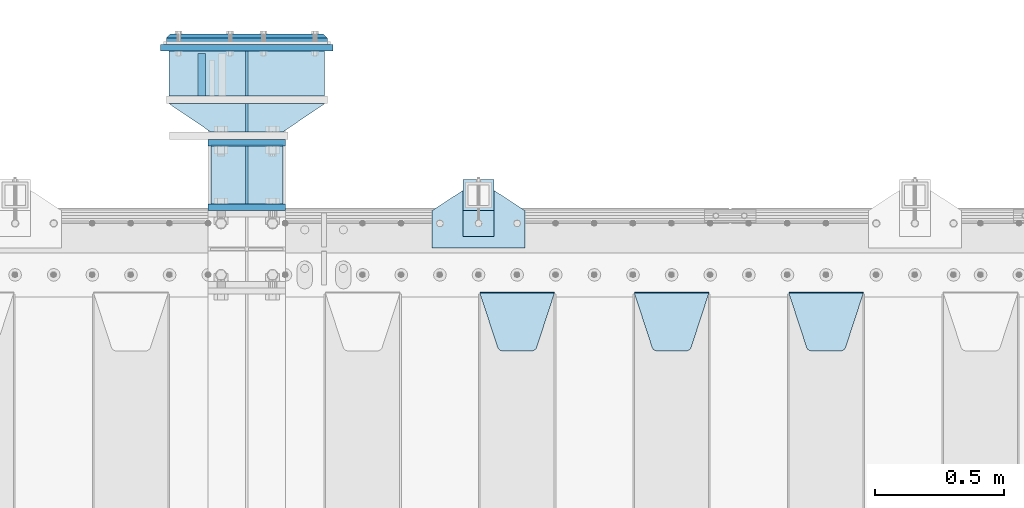
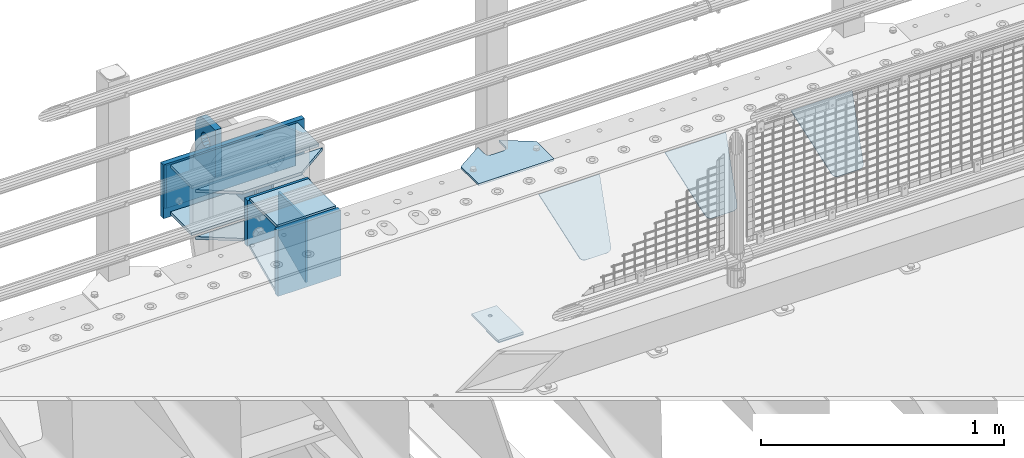
# One storey, part 232 of 257: 20 plates.
"""IFC2X3 building model written with IfcOpenShell, lengths in millimetres."""

from ifc_helpers import new_model, si_unit, frame, origin_with_axes, place, context, subcontext, project, spatial, faceted_brep, material, type_object, element, save


model = new_model("IFC2X3")

# Units and contexts
model_context = context("Model", 3, precision=1e-05, world=origin_with_axes())
body_context = subcontext(model_context, "Body", "Model", "MODEL_VIEW")
ifc_project = project(units=[si_unit("LENGTHUNIT", "METRE", prefix="MILLI"), si_unit("AREAUNIT", "SQUARE_METRE"), si_unit("VOLUMEUNIT", "CUBIC_METRE"), si_unit("MASSUNIT", "GRAM", prefix="KILO"), si_unit("TIMEUNIT", "SECOND"), si_unit("PLANEANGLEUNIT", "RADIAN"), si_unit("SOLIDANGLEUNIT", "STERADIAN"), si_unit("THERMODYNAMICTEMPERATUREUNIT", "DEGREE_CELSIUS"), si_unit("LUMINOUSINTENSITYUNIT", "LUMEN")], contexts=[model_context])

# Site, building, storey
site_placement = place(None, origin_with_axes())
site = spatial("IfcSite", under=ifc_project, at=site_placement, CompositionType="ELEMENT")
building_placement = place(site_placement, origin_with_axes())
building = spatial("IfcBuilding", under=site, at=building_placement, Name="Standard", CompositionType="ELEMENT")
storey_placement = place(building_placement, origin_with_axes())
storey = spatial("IfcBuildingStorey", under=building, at=storey_placement, Name="Undefined", CompositionType="ELEMENT", Elevation=0.0)

# Plates
ifc_material_1 = material(Name="STEEL/S355N")
plate_type_1 = type_object("IfcPlateType", PredefinedType="NOTDEFINED")
plate_1_placement = place(storey_placement, frame((54524.4999994828, 12595.0000000407, -1.9536520994734e-05), z_axis=(0.0, 1.0, 0.0), x_axis=(0.0, 0.0, 1.0)))
element("IfcPlate", 1, at=plate_1_placement, inside=storey, type_object=plate_type_1, material=ifc_material_1, context=body_context, shape_type="Brep", body=[
    faceted_brep([(125.840713002475, 15.0000005560505, 114.183542552877), (125.840713002475, -14.9999994439495, 114.183542852878), (113.837049096081, -14.9999995241524, 106.162951053862), (113.837049096081, 15.0000004758476, 106.162950753862), (105.816457297066, -14.9999996441911, 94.1592871474677), (105.816457297066, 15.0000003558089, 94.1592868474672), (102.999999999984, -14.9999997857813, 80.0000001499593), (102.999999999984, 15.0000002142187, 79.9999998499588), (105.816457297066, -14.9999999273787, 65.8407131524509), (105.816457297066, 15.0000000726213, 65.8407128524505), (113.837049096081, -15.0000000474101, 53.8370492460563), (113.837049096081, 14.9999999525899, 53.8370489460558), (125.840713002475, -15.0000001276203, 45.8164574470411), (125.840713002475, 14.9999998723797, 45.8164571470406), (139.999999999984, -15.0000001557855, 43.0000001499593), (139.999999999984, 14.9999998442145, 42.9999998499588), (154.159286997492, -15.0000001276203, 45.8164574470411), (154.159286997492, 14.9999998723797, 45.8164571470406), (166.162950903886, -15.0000000474101, 53.8370492460563), (166.162950903886, 14.9999999525899, 53.8370489460558), (174.183542702901, -14.9999999273787, 65.8407131524509), (174.183542702901, 15.0000000726213, 65.8407128524505), (176.999999999984, -14.9999997857813, 80.0000001499593), (176.999999999984, 15.0000002142187, 79.9999998499588), (174.183542702901, -14.9999996441911, 94.1592871474677), (174.183542702901, 15.0000003558089, 94.1592868474672), (166.162950903886, -14.9999995241524, 106.162951053862), (166.162950903886, 15.0000004758476, 106.162950753862), (154.159286997492, -14.9999994439495, 114.183542852878), (154.159286997492, 15.0000005560505, 114.183542552877), (139.999999999984, -14.9999994157843, 117.000000149959), (139.999999999984, 15.0000005842157, 116.999999849959), (-1.40620068123098e-06, -14.9999999999927, 165.000000000002), (170.0, -14.9999999999927, 165.0), (170.0, 15.0000000000073, 165.000000000002), (-1.40620068123098e-06, 15.0000000000073, 165.000000000002), (188.117333157176, -14.9999999999927, 162.614807840235), (188.117333157176, 15.0000000000073, 162.614807840237), (205.0, -14.9999999999927, 155.621778264911), (205.0, 15.0000000000073, 155.621778264911), (219.497474683058, -14.9999999999927, 144.497474683059), (219.497474683058, 15.0000000000073, 144.497474683059), (230.621778264911, -14.9999999999927, 130.0), (230.621778264911, 15.0000000000073, 130.000000000002), (237.614807840235, -14.9999999999927, 113.117333157177), (237.614807840235, 15.0000000000073, 113.117333157177), (240.0, -14.9999999999927, 95.0), (240.0, 15.0000000000073, 95.0000000000018), (240.000015258789, -14.9999999999927, -2.03726813197136e-10), (240.000015258789, 15.0000000000073, -2.05545802600682e-10), (0.0, -15.0, 0.0), (0.0, 15.0, 0.0)], [[[0, 1, 2, 3]], [[3, 2, 4, 5]], [[5, 4, 6, 7]], [[7, 6, 8, 9]], [[9, 8, 10, 11]], [[11, 10, 12, 13]], [[13, 12, 14, 15]], [[15, 14, 16, 17]], [[17, 16, 18, 19]], [[19, 18, 20, 21]], [[21, 20, 22, 23]], [[23, 22, 24, 25]], [[25, 24, 26, 27]], [[27, 26, 28, 29]], [[29, 28, 30, 31]], [[31, 30, 1, 0]], [[32, 33, 34, 35]], [[33, 36, 37, 34]], [[36, 38, 39, 37]], [[38, 40, 41, 39]], [[40, 42, 43, 41]], [[42, 44, 45, 43]], [[44, 46, 47, 45]], [[46, 48, 49, 47]], [[48, 50, 51, 49]], [[34, 37, 39, 41, 43, 45, 47, 49, 51, 35], [3, 5, 7, 9, 11, 13, 15, 17, 19, 21, 23, 25, 27, 29, 31, 0]], [[50, 32, 35, 51]], [[48, 46, 44, 42, 40, 38, 36, 33, 32, 50], [26, 24, 22, 20, 18, 16, 14, 12, 10, 8, 6, 4, 2, 1, 30, 28]]]),
])
plate_type_2 = type_object("IfcPlateType", PredefinedType="NOTDEFINED")
plate_2_placement = place(storey_placement, frame((54550.0, 12162.5000000042, -340.000019536857), z_axis=(0.0, 0.0, 1.0), x_axis=(1.0, 0.0, 0.0)))
element("IfcPlate", 2, at=plate_2_placement, inside=storey, type_object=plate_type_2, material=ifc_material_1, context=body_context, shape_type="Brep", body=[
    faceted_brep([(0.0, -12.5, 0.0), (0.0, -12.5, 330.0), (0.0, 12.5, 330.0), (0.0, 12.5, 0.0), (300.0, -12.5, 330.0), (300.0, 12.5, 330.0), (300.0, -12.5, 0.0), (300.0, 12.5, 0.0)], [[[0, 1, 2, 3]], [[1, 4, 5, 2]], [[4, 6, 7, 5]], [[6, 0, 3, 7]], [[5, 7, 3, 2]], [[6, 4, 1, 0]]]),
])
plate_type_3 = type_object("IfcPlateType", PredefinedType="NOTDEFINED")
plate_3_placement = place(storey_placement, frame((56805.0, 11831.7677669559, -1.767766952965), z_axis=(0.0, -0.707106781186548, -0.707106781186547), x_axis=(1.0, 0.0, 0.0)))
element("IfcPlate", 3, at=plate_3_placement, inside=storey, type_object=plate_type_3, material=ifc_material_1, context=body_context, shape_type="Brep", body=[
    faceted_brep([(0.0, -2.5, 0.0), (69.345504679477, -2.50000000000091, 300.17173142483), (69.345504679477, 2.5, 300.171731424831), (0.0, 2.5, 0.0), (70.927406119954, -2.50000000000091, 304.8974424154), (70.927406119954, 2.5, 304.8974424154), (73.3818627772271, -2.50000000000091, 309.234538108527), (73.3818627772271, 2.49999999999909, 309.234538108527), (76.6187032999587, -2.5, 313.023683126103), (76.6187032999587, 2.5, 313.023683126103), (80.5190132705029, -2.5, 316.125672595372), (80.5190132705029, 2.5, 316.125672595371), (84.9395038596849, -2.5, 318.426546230476), (84.9395038596849, 2.5, 318.426546230477), (89.7177759439219, -2.5, 319.841774983275), (89.7177759439219, 2.5, 319.841774983275), (94.6782862926484, -2.5, 320.319366455079), (94.6782862926484, 2.5, 320.319366455079), (195.321713707352, -2.5, 320.319366455079), (195.321713707352, 2.5, 320.319366455079), (200.282224056078, -2.5, 319.841774983275), (200.282224056078, 2.49999999999909, 319.841774983275), (205.060496140315, -2.5, 318.426546230476), (205.060496140315, 2.49999999999909, 318.426546230475), (209.480986729497, -2.5, 316.125672595371), (209.480986729497, 2.5, 316.125672595371), (213.381296700041, -2.50000000000091, 313.023683126102), (213.381296700041, 2.5, 313.023683126103), (216.618137222766, -2.50000000000091, 309.234538108527), (216.618137222766, 2.5, 309.234538108527), (219.072593880039, -2.5, 304.897442415399), (219.072593880039, 2.5, 304.897442415399), (220.654495320523, -2.50000000000091, 300.17173142483), (220.654495320523, 2.5, 300.171731424831), (290.0, -2.50000000000091, 0.0), (290.0, 2.5, 9.09494701772928e-13)], [[[0, 1, 2, 3]], [[1, 4, 5, 2]], [[4, 6, 7, 5]], [[6, 8, 9, 7]], [[8, 10, 11, 9]], [[10, 12, 13, 11]], [[12, 14, 15, 13]], [[14, 16, 17, 15]], [[16, 18, 19, 17]], [[18, 20, 21, 19]], [[20, 22, 23, 21]], [[22, 24, 25, 23]], [[24, 26, 27, 25]], [[26, 28, 29, 27]], [[28, 30, 31, 29]], [[30, 32, 33, 31]], [[32, 34, 35, 33]], [[34, 0, 3, 35]], [[5, 7, 9, 11, 13, 15, 17, 19, 21, 23, 25, 27, 29, 31, 33, 35, 3, 2]], [[34, 32, 30, 28, 26, 24, 22, 20, 18, 16, 14, 12, 10, 8, 6, 4, 1, 0]]]),
])
plate_4_placement = place(storey_placement, frame((56205.0, 11831.7677669559, -1.767766952965), z_axis=(0.0, -0.707106781186548, -0.707106781186547), x_axis=(1.0, 0.0, 0.0)))
element("IfcPlate", 4, at=plate_4_placement, inside=storey, type_object=plate_type_3, material=ifc_material_1, context=body_context, shape_type="Brep", body=[
    faceted_brep([(0.0, -2.5, 0.0), (69.345504679477, -2.50000000000091, 300.17173142483), (69.345504679477, 2.5, 300.171731424831), (0.0, 2.5, 0.0), (70.927406119954, -2.50000000000091, 304.8974424154), (70.927406119954, 2.5, 304.8974424154), (73.3818627772271, -2.50000000000091, 309.234538108527), (73.3818627772271, 2.49999999999909, 309.234538108527), (76.6187032999587, -2.5, 313.023683126103), (76.6187032999587, 2.5, 313.023683126103), (80.5190132705029, -2.5, 316.125672595372), (80.5190132705029, 2.5, 316.125672595371), (84.9395038596849, -2.5, 318.426546230476), (84.9395038596849, 2.5, 318.426546230477), (89.7177759439219, -2.5, 319.841774983275), (89.7177759439219, 2.5, 319.841774983275), (94.6782862926484, -2.5, 320.319366455079), (94.6782862926484, 2.5, 320.319366455079), (195.321713707352, -2.5, 320.319366455079), (195.321713707352, 2.5, 320.319366455079), (200.282224056078, -2.5, 319.841774983275), (200.282224056078, 2.49999999999909, 319.841774983275), (205.060496140315, -2.5, 318.426546230476), (205.060496140315, 2.49999999999909, 318.426546230475), (209.480986729497, -2.5, 316.125672595371), (209.480986729497, 2.5, 316.125672595371), (213.381296700041, -2.50000000000091, 313.023683126102), (213.381296700041, 2.5, 313.023683126103), (216.618137222766, -2.50000000000091, 309.234538108527), (216.618137222766, 2.5, 309.234538108527), (219.072593880039, -2.5, 304.897442415399), (219.072593880039, 2.5, 304.897442415399), (220.654495320523, -2.50000000000091, 300.17173142483), (220.654495320523, 2.5, 300.171731424831), (290.0, -2.50000000000091, 0.0), (290.0, 2.5, 9.09494701772928e-13)], [[[0, 1, 2, 3]], [[1, 4, 5, 2]], [[4, 6, 7, 5]], [[6, 8, 9, 7]], [[8, 10, 11, 9]], [[10, 12, 13, 11]], [[12, 14, 15, 13]], [[14, 16, 17, 15]], [[16, 18, 19, 17]], [[18, 20, 21, 19]], [[20, 22, 23, 21]], [[22, 24, 25, 23]], [[24, 26, 27, 25]], [[26, 28, 29, 27]], [[28, 30, 31, 29]], [[30, 32, 33, 31]], [[32, 34, 35, 33]], [[34, 0, 3, 35]], [[5, 7, 9, 11, 13, 15, 17, 19, 21, 23, 25, 27, 29, 31, 33, 35, 3, 2]], [[34, 32, 30, 28, 26, 24, 22, 20, 18, 16, 14, 12, 10, 8, 6, 4, 1, 0]]]),
])
plate_5_placement = place(storey_placement, frame((55605.0, 11831.7677669559, -1.767766952965), z_axis=(0.0, -0.707106781186548, -0.707106781186547), x_axis=(1.0, 0.0, 0.0)))
element("IfcPlate", 5, at=plate_5_placement, inside=storey, type_object=plate_type_3, material=ifc_material_1, context=body_context, shape_type="Brep", body=[
    faceted_brep([(0.0, -2.5, 0.0), (69.345504679477, -2.50000000000091, 300.17173142483), (69.345504679477, 2.5, 300.171731424831), (0.0, 2.5, 0.0), (70.927406119954, -2.50000000000091, 304.8974424154), (70.927406119954, 2.5, 304.8974424154), (73.3818627772271, -2.50000000000091, 309.234538108527), (73.3818627772271, 2.49999999999909, 309.234538108527), (76.6187032999587, -2.5, 313.023683126103), (76.6187032999587, 2.5, 313.023683126103), (80.5190132705029, -2.5, 316.125672595372), (80.5190132705029, 2.5, 316.125672595371), (84.9395038596849, -2.5, 318.426546230476), (84.9395038596849, 2.5, 318.426546230477), (89.7177759439219, -2.5, 319.841774983275), (89.7177759439219, 2.5, 319.841774983275), (94.6782862926484, -2.5, 320.319366455079), (94.6782862926484, 2.5, 320.319366455079), (195.321713707352, -2.5, 320.319366455079), (195.321713707352, 2.5, 320.319366455079), (200.282224056078, -2.5, 319.841774983275), (200.282224056078, 2.49999999999909, 319.841774983275), (205.060496140315, -2.5, 318.426546230476), (205.060496140315, 2.49999999999909, 318.426546230475), (209.480986729497, -2.5, 316.125672595371), (209.480986729497, 2.5, 316.125672595371), (213.381296700041, -2.50000000000091, 313.023683126102), (213.381296700041, 2.5, 313.023683126103), (216.618137222766, -2.50000000000091, 309.234538108527), (216.618137222766, 2.5, 309.234538108527), (219.072593880039, -2.5, 304.897442415399), (219.072593880039, 2.5, 304.897442415399), (220.654495320523, -2.50000000000091, 300.17173142483), (220.654495320523, 2.5, 300.171731424831), (290.0, -2.50000000000091, 0.0), (290.0, 2.5, 9.09494701772928e-13)], [[[0, 1, 2, 3]], [[1, 4, 5, 2]], [[4, 6, 7, 5]], [[6, 8, 9, 7]], [[8, 10, 11, 9]], [[10, 12, 13, 11]], [[12, 14, 15, 13]], [[14, 16, 17, 15]], [[16, 18, 19, 17]], [[18, 20, 21, 19]], [[20, 22, 23, 21]], [[22, 24, 25, 23]], [[24, 26, 27, 25]], [[26, 28, 29, 27]], [[28, 30, 31, 29]], [[30, 32, 33, 31]], [[32, 34, 35, 33]], [[34, 0, 3, 35]], [[5, 7, 9, 11, 13, 15, 17, 19, 21, 23, 25, 27, 29, 31, 33, 35, 3, 2]], [[34, 32, 30, 28, 26, 24, 22, 20, 18, 16, 14, 12, 10, 8, 6, 4, 1, 0]]]),
])
ifc_material_2 = material(Name="STEEL/S355J2")
plate_type_4 = type_object("IfcPlateType", PredefinedType="NOTDEFINED")
plate_6_placement = place(storey_placement, frame((55420.0, 12005.0, 5.00000000004911), z_axis=(0.0, 1.0, 0.0), x_axis=(1.0, 0.0, 0.0)))
element("IfcPlate", 6, at=plate_6_placement, inside=storey, type_object=plate_type_4, material=ifc_material_2, context=body_context, shape_type="Brep", body=[
    faceted_brep([(0.0, -5.0, 0.0), (2.31396552408114e-06, -5.0, 145.0), (2.31396552408114e-06, 5.0, 145.0), (0.0, 5.0, 0.0), (130.0, -5.0, 230.0), (130.0, 5.0, 230.0), (130.0, -5.0, 180.0), (130.0, 5.0, 180.0), (130.48036798992, -5.0, 175.122741949597), (130.48036798992, 5.0, 175.122741949597), (131.903011687216, -5.0, 170.432914190873), (131.903011687216, 5.0, 170.432914190873), (134.213259692435, -5.0, 166.11074417451), (134.213259692435, 5.0, 166.11074417451), (137.322330470335, -5.0, 162.322330470337), (137.322330470335, 5.0, 162.322330470337), (141.110744174512, -5.0, 159.213259692437), (141.110744174512, 5.0, 159.213259692437), (145.432914190875, -5.0, 156.903011687218), (145.432914190875, 5.0, 156.903011687218), (150.122741949599, -5.0, 155.48036798992), (150.122741949599, 5.0, 155.48036798992), (155.0, -5.0, 155.0), (155.0, 5.0, 155.0), (205.0, -5.0, 155.0), (205.0, 5.0, 155.0), (209.877258050401, -5.0, 155.48036798992), (209.877258050401, 5.0, 155.48036798992), (214.567085809125, -5.0, 156.903011687218), (214.567085809125, 5.0, 156.903011687218), (218.889255825488, -5.0, 159.213259692437), (218.889255825488, 5.0, 159.213259692437), (222.677669529665, -5.0, 162.322330470337), (222.677669529665, 5.0, 162.322330470337), (225.786740307565, -5.0, 166.11074417451), (225.786740307565, 5.0, 166.11074417451), (228.096988312784, -5.0, 170.432914190873), (228.096988312784, 5.0, 170.432914190873), (229.51963201008, -5.0, 175.122741949597), (229.51963201008, 5.0, 175.122741949597), (230.0, -5.0, 180.0), (230.0, 5.0, 180.0), (230.0, -5.0, 230.0), (230.0, 5.0, 230.0), (360.0, -5.0, 145.0), (360.0, 5.0, 145.0), (360.0, -5.0, -7.27595761418343e-12), (360.0, 5.0, -7.27595761418343e-12)], [[[0, 1, 2, 3]], [[1, 4, 5, 2]], [[4, 6, 7, 5]], [[6, 8, 9, 7]], [[8, 10, 11, 9]], [[10, 12, 13, 11]], [[12, 14, 15, 13]], [[14, 16, 17, 15]], [[16, 18, 19, 17]], [[18, 20, 21, 19]], [[20, 22, 23, 21]], [[22, 24, 25, 23]], [[24, 26, 27, 25]], [[26, 28, 29, 27]], [[28, 30, 31, 29]], [[30, 32, 33, 31]], [[32, 34, 35, 33]], [[34, 36, 37, 35]], [[36, 38, 39, 37]], [[38, 40, 41, 39]], [[40, 42, 43, 41]], [[42, 44, 45, 43]], [[44, 46, 47, 45]], [[46, 0, 3, 47]], [[5, 7, 9, 11, 13, 15, 17, 19, 21, 23, 25, 27, 29, 31, 33, 35, 37, 39, 41, 43, 45, 47, 3, 2]], [[46, 44, 42, 40, 38, 36, 34, 32, 30, 28, 26, 24, 22, 20, 18, 16, 14, 12, 10, 8, 6, 4, 1, 0]]]),
])
plate_type_5 = type_object("IfcPlateType", PredefinedType="NOTDEFINED")
plate_7_placement = place(storey_placement, frame((55540.0000000001, 12050.0000000002, -850.000000000002), z_axis=(0.0, 1.0, 0.0), x_axis=(1.0, 0.0, 0.0)))
element("IfcPlate", 7, at=plate_7_placement, inside=storey, type_object=plate_type_5, material=ifc_material_2, context=body_context, shape_type="Brep", body=[
    faceted_brep([(66.3639610305399, -5.0, 163.636038969113), (66.3639610305399, 5.0, 163.636038969113), (59.9999999998618, 5.0, 160.999999999791), (59.9999999998618, -5.0, 160.999999999791), (53.6360389691836, 5.0, 163.636038969113), (53.6360389691836, -5.0, 163.636038969113), (50.9999999998618, 5.0, 169.999999999791), (50.9999999998618, -5.0, 169.999999999791), (53.6360389691836, 5.0, 176.363961030469), (53.6360389691836, -5.0, 176.363961030469), (59.9999999998618, 5.0, 178.999999999791), (59.9999999998618, -5.0, 178.999999999791), (66.3639610305399, 5.0, 176.363961030469), (66.3639610305399, -5.0, 176.363961030469), (68.9999999998618, 5.0, 169.999999999791), (68.9999999998618, -5.0, 169.999999999791), (120.0, -5.0, 0.0), (120.0, -5.0, 220.0), (0.0, -5.0, 220.0), (0.0, -5.0, 0.0), (0.0, 5.0, 0.0), (120.0, 5.0, 0.0), (120.0, 5.0, 220.0), (0.0, 5.0, 220.0)], [[[0, 1, 2, 3]], [[3, 2, 4, 5]], [[5, 4, 6, 7]], [[7, 6, 8, 9]], [[9, 8, 10, 11]], [[11, 10, 12, 13]], [[13, 12, 14, 15]], [[15, 14, 1, 0]], [[16, 17, 18, 19], [3, 5, 7, 9, 11, 13, 15, 0]], [[16, 19, 20, 21]], [[17, 16, 21, 22]], [[18, 17, 22, 23]], [[19, 18, 23, 20]], [[22, 21, 20, 23], [10, 8, 6, 4, 2, 1, 14, 12]]]),
])
plate_type_6 = type_object("IfcPlateType", PredefinedType="NOTDEFINED")
plate_8_placement = place(storey_placement, frame((55540.0000000001, 12050.0000000002, -857.500000000002), z_axis=(0.0, 1.0, 0.0), x_axis=(1.0, 0.0, 0.0)))
element("IfcPlate", 8, at=plate_8_placement, inside=storey, type_object=plate_type_6, material=ifc_material_2, context=body_context, shape_type="Brep", body=[
    faceted_brep([(0.0, -2.5, 0.0), (0.0, -2.5, 100.0), (0.0, 2.5, 100.0), (0.0, 2.5, 0.0), (120.0, -2.5, 100.0), (120.0, 2.5, 100.0), (120.0, -2.5, 0.0), (120.0, 2.5, 0.0)], [[[0, 1, 2, 3]], [[1, 4, 5, 2]], [[4, 6, 7, 5]], [[6, 0, 3, 7]], [[5, 7, 3, 2]], [[6, 4, 1, 0]]]),
])
plate_type_7 = type_object("IfcPlateType", PredefinedType="NOTDEFINED")
plate_9_placement = place(storey_placement, frame((54700.0, 12565.0000000042, -14.0000195368567), z_axis=(0.0, 0.0, -1.0), x_axis=(0.0, -1.0, 0.0)))
element("IfcPlate", 9, at=plate_9_placement, inside=storey, type_object=plate_type_7, material=ifc_material_1, context=body_context, shape_type="Brep", body=[
    faceted_brep([(0.0, -5.0, 0.0), (0.0, -5.0, 222.0), (0.0, 5.0, 222.0), (0.0, 5.0, 0.0), (110.0, -5.0, 222.0), (110.0, 5.0, 222.0), (110.0, -5.0, 0.0), (110.0, 5.0, 0.0)], [[[0, 1, 2, 3]], [[1, 4, 5, 2]], [[4, 6, 7, 5]], [[6, 0, 3, 7]], [[5, 7, 3, 2]], [[6, 4, 1, 0]]]),
])
plate_type_8 = type_object("IfcPlateType", PredefinedType="NOTDEFINED")
for number, where, z_axis, x_axis in (
    (10, (55002.5, 12565.0000000042, -7.00001953685671), (-0.560566412034006, 0.828109472050236, 0.0), (-0.828109472050236, -0.560566412034006, 0.0)),
    (11, (55002.5, 12565.0000000042, -243.000019536857), (-0.560566412034006, 0.828109472050236, 0.0), (-0.828109472050236, -0.560566412034006, 0.0)),
):
    element("IfcPlate", number, at=place(storey_placement, frame(where, z_axis=z_axis, x_axis=x_axis)), inside=storey, type_object=plate_type_8, material=ifc_material_1, context=body_context, shape_type="Brep", body=[
        faceted_brep([(0.0, -7.0, 0.0), (501.00622558593, -7.0, 339.142669677727), (501.00622558593, 7.0, 339.142669677727), (0.0, 7.0, 0.0), (428.100738525376, -7.0, 156.958602905266), (428.100738525376, 7.0, 156.958602905266), (196.230087280266, -7.0, -4.36557456851006e-11), (196.230087280266, 7.0, -4.36557456851006e-11)], [[[0, 1, 2, 3]], [[1, 4, 5, 2]], [[4, 6, 7, 5]], [[6, 0, 3, 7]], [[5, 7, 3, 2]], [[6, 4, 1, 0]]]),
    ])
ifc_material_3 = material()
plate_type_9 = type_object("IfcPlateType", PredefinedType="NOTDEFINED")
for number, where, z_axis, x_axis in (
    (12, (55002.5, 12595.0000000042, -243.000019536857), (0.0, 1.0, 0.0), (-1.0, 0.0, 0.0)),
    (13, (55002.5, 12595.0000000042, -7.00001953685671), (0.0, 1.0, 0.0), (-1.0, 0.0, 0.0)),
):
    element("IfcPlate", number, at=place(storey_placement, frame(where, z_axis=z_axis, x_axis=x_axis)), inside=storey, type_object=plate_type_9, material=ifc_material_3, context=body_context, shape_type="Brep", body=[
        faceted_brep([(0.0, -7.0, 0.0), (0.0, -7.0, 175.0), (0.0, 7.0, 175.0), (0.0, 7.0, 0.0), (605.0, -7.0, 175.0), (605.0, 7.0, 175.0), (605.0, -7.0, 0.0), (605.0, 7.0, 0.0)], [[[0, 1, 2, 3]], [[1, 4, 5, 2]], [[4, 6, 7, 5]], [[6, 0, 3, 7]], [[5, 7, 3, 2]], [[6, 4, 1, 0]]]),
    ])
plate_type_10 = type_object("IfcPlateType", PredefinedType="NOTDEFINED")
plate_10_placement = place(storey_placement, frame((55035.0, 12782.5000000042, 9.99998046314329), z_axis=(0.0, 0.0, -1.0), x_axis=(-1.0, 0.0, 0.0)))
element("IfcPlate", 14, at=plate_10_placement, inside=storey, type_object=plate_type_10, material=ifc_material_1, context=body_context, shape_type="Brep", body=[
    faceted_brep([(0.0, -12.5, 0.0), (0.0, -12.5, 270.0), (0.0, 12.5, 270.0), (0.0, 12.5, 0.0), (670.0, -12.5, 270.0), (670.0, 12.5, 270.0), (670.0, -12.5, 0.0), (670.0, 12.5, 0.0)], [[[0, 1, 2, 3]], [[1, 4, 5, 2]], [[4, 6, 7, 5]], [[6, 0, 3, 7]], [[5, 7, 3, 2]], [[6, 4, 1, 0]]]),
])
plate_type_11 = type_object("IfcPlateType", PredefinedType="NOTDEFINED")
plate_11_placement = place(storey_placement, frame((54700.0, 12770.0000000042, -14.0000195368567), z_axis=(0.0, 0.0, -1.0), x_axis=(0.0, -1.0, 0.0)))
element("IfcPlate", 15, at=plate_11_placement, inside=storey, type_object=plate_type_11, material=ifc_material_1, context=body_context, shape_type="Brep", body=[
    faceted_brep([(0.0, -5.0, 0.0), (0.0, -5.0, 222.0), (0.0, 5.0, 222.0), (0.0, 5.0, 0.0), (175.0, -5.0, 222.0), (175.0, 5.0, 222.0), (175.0, -5.0, 0.0), (175.0, 5.0, 0.0)], [[[0, 1, 2, 3]], [[1, 4, 5, 2]], [[4, 6, 7, 5]], [[6, 0, 3, 7]], [[5, 7, 3, 2]], [[6, 4, 1, 0]]]),
])
plate_type_12 = type_object("IfcPlateType", PredefinedType="NOTDEFINED")
plate_12_placement = place(storey_placement, frame((54550.0, 12412.5000000042, -240.000019536857), z_axis=(0.0, 0.0, 1.0), x_axis=(1.0, 0.0, 0.0)))
element("IfcPlate", 16, at=plate_12_placement, inside=storey, type_object=plate_type_12, material=ifc_material_1, context=body_context, shape_type="Brep", body=[
    faceted_brep([(0.0, -12.5, 0.0), (0.0, -12.5, 230.0), (0.0, 12.5, 230.0), (0.0, 12.5, 0.0), (300.0, -12.5, 230.0), (300.0, 12.5, 230.0), (300.0, -12.5, 0.0), (300.0, 12.5, 0.0)], [[[0, 1, 2, 3]], [[1, 4, 5, 2]], [[4, 6, 7, 5]], [[6, 0, 3, 7]], [[5, 7, 3, 2]], [[6, 4, 1, 0]]]),
])
ifc_material_4 = material()
plate_type_13 = type_object("IfcPlateType", PredefinedType="NOTDEFINED")
plate_13_placement = place(storey_placement, frame((55012.5, 12815.0000000042, -12.5000195368567), z_axis=(0.0, 0.0, -1.0), x_axis=(-1.0, 0.0, 0.0)))
element("IfcPlate", 17, at=plate_13_placement, inside=storey, type_object=plate_type_13, material=ifc_material_4, context=body_context, shape_type="Brep", body=[
    faceted_brep([(0.0, -15.0, 0.0), (5.0, -20.0, 5.0), (5.0, -20.0, 220.0), (0.0, -15.0, 225.0), (625.0, -15.0, 0.0), (620.0, -20.0, 5.0), (620.0, -20.0, 220.0), (625.0, -15.0, 225.0), (15.0, 20.0, 15.0), (0.0, 5.0, 0.0), (0.0, 5.0, 225.0), (15.0, 20.0, 210.0), (625.0, 5.0, 225.0), (610.0, 20.0, 210.0), (625.0, 5.0, 0.0), (610.0, 20.0, 15.0), (64.8205080756888, -5.0, 167.5), (57.5, -5.0, 160.179491924311), (47.5, -5.0, 157.5), (37.5, -5.0, 160.179491924311), (30.1794919243112, -5.0, 167.5), (27.5, -5.0, 177.5), (30.1794919243112, -5.0, 187.5), (37.5, -5.0, 194.820508075689), (47.5, -5.0, 197.5), (57.5, -5.0, 194.820508075689), (64.8205080756888, -5.0, 187.5), (67.5, -5.0, 177.5), (37.5, 20.0, 194.820508075689), (30.1794919243112, 20.0, 187.5), (47.5, 20.0, 197.5), (57.5, 20.0, 194.820508075689), (64.8205080756888, 20.0, 187.5), (67.5, 20.0, 177.5), (64.8205080756888, 20.0, 167.5), (57.5, 20.0, 160.179491924311), (47.5, 20.0, 157.5), (37.5, 20.0, 160.179491924311), (30.1794919243112, 20.0, 167.5), (27.5, 20.0, 177.5), (64.8205080756888, -5.0, 37.5), (57.5, -5.0, 30.1794919243112), (47.5, -5.0, 27.5), (37.5, -5.0, 30.1794919243112), (30.1794919243112, -5.0, 37.5), (27.5, -5.0, 47.5), (30.1794919243112, -5.0, 57.5), (37.5, -5.0, 64.8205080756888), (47.5, -5.0, 67.5), (57.5, -5.0, 64.8205080756888), (64.8205080756888, -5.0, 57.5), (67.5, -5.0, 47.5), (30.1794919243112, 20.0, 57.5), (27.5, 20.0, 47.5), (37.5, 20.0, 64.8205080756888), (47.5, 20.0, 67.5), (57.5, 20.0, 64.8205080756888), (64.8205080756888, 20.0, 57.5), (67.5, 20.0, 47.5), (64.8205080756888, 20.0, 37.5), (57.5, 20.0, 30.1794919243112), (47.5, 20.0, 27.5), (37.5, 20.0, 30.1794919243112), (30.1794919243112, 20.0, 37.5), (264.820508075689, -5.0, 37.5), (257.5, -5.0, 30.1794919243112), (247.5, -5.0, 27.5), (237.5, -5.0, 30.1794919243112), (230.179491924311, -5.0, 37.5), (227.5, -5.0, 47.5), (230.179491924311, -5.0, 57.5), (237.5, -5.0, 64.8205080756888), (247.5, -5.0, 67.5), (257.5, -5.0, 64.8205080756888), (264.820508075689, -5.0, 57.5), (267.5, -5.0, 47.5), (230.179491924311, 20.0, 57.5), (227.5, 20.0, 47.5), (237.5, 20.0, 64.8205080756888), (247.5, 20.0, 67.5), (257.5, 20.0, 64.8205080756888), (264.820508075689, 20.0, 57.5), (267.5, 20.0, 47.5), (264.820508075689, 20.0, 37.5), (257.5, 20.0, 30.1794919243112), (247.5, 20.0, 27.5), (237.5, 20.0, 30.1794919243112), (230.179491924311, 20.0, 37.5), (394.820508075689, -5.0, 37.5), (387.5, -5.0, 30.1794919243112), (377.5, -5.0, 27.5), (367.5, -5.0, 30.1794919243112), (360.179491924311, -5.0, 37.5), (357.5, -5.0, 47.5), (360.179491924311, -5.0, 57.5), (367.5, -5.0, 64.8205080756888), (377.5, -5.0, 67.5), (387.5, -5.0, 64.8205080756888), (394.820508075689, -5.0, 57.5), (397.5, -5.0, 47.5), (360.179491924311, 20.0, 57.5), (357.5, 20.0, 47.5), (367.5, 20.0, 64.8205080756888), (377.5, 20.0, 67.5), (387.5, 20.0, 64.8205080756888), (394.820508075689, 20.0, 57.5), (397.5, 20.0, 47.5), (394.820508075689, 20.0, 37.5), (387.5, 20.0, 30.1794919243112), (377.5, 20.0, 27.5), (367.5, 20.0, 30.1794919243112), (360.179491924311, 20.0, 37.5), (594.820508075689, -5.0, 37.5), (587.5, -5.0, 30.1794919243112), (577.5, -5.0, 27.5), (567.5, -5.0, 30.1794919243112), (560.179491924311, -5.0, 37.5), (557.5, -5.0, 47.5), (560.179491924311, -5.0, 57.5), (567.5, -5.0, 64.8205080756888), (577.5, -5.0, 67.5), (587.5, -5.0, 64.8205080756888), (594.820508075689, -5.0, 57.5), (597.5, -5.0, 47.5), (560.179491924311, 20.0, 57.5), (557.5, 20.0, 47.5), (567.5, 20.0, 64.8205080756888), (577.5, 20.0, 67.5), (587.5, 20.0, 64.8205080756888), (594.820508075689, 20.0, 57.5), (597.5, 20.0, 47.5), (594.820508075689, 20.0, 37.5), (587.5, 20.0, 30.1794919243112), (577.5, 20.0, 27.5), (567.5, 20.0, 30.1794919243112), (560.179491924311, 20.0, 37.5), (594.820508075689, -5.0, 167.5), (587.5, -5.0, 160.179491924311), (577.5, -5.0, 157.5), (567.5, -5.0, 160.179491924311), (560.179491924311, -5.0, 167.5), (557.5, -5.0, 177.5), (560.179491924311, -5.0, 187.5), (567.5, -5.0, 194.820508075689), (577.5, -5.0, 197.5), (587.5, -5.0, 194.820508075689), (594.820508075689, -5.0, 187.5), (597.5, -5.0, 177.5), (560.179491924311, 20.0, 187.5), (557.5, 20.0, 177.5), (567.5, 20.0, 194.820508075689), (577.5, 20.0, 197.5), (587.5, 20.0, 194.820508075689), (594.820508075689, 20.0, 187.5), (597.5, 20.0, 177.5), (594.820508075689, 20.0, 167.5), (587.5, 20.0, 160.179491924311), (577.5, 20.0, 157.5), (567.5, 20.0, 160.179491924311), (560.179491924311, 20.0, 167.5), (394.820508075689, -5.0, 167.5), (387.5, -5.0, 160.179491924311), (377.5, -5.0, 157.5), (367.5, -5.0, 160.179491924311), (360.179491924311, -5.0, 167.5), (357.5, -5.0, 177.5), (360.179491924311, -5.0, 187.5), (367.5, -5.0, 194.820508075689), (377.5, -5.0, 197.5), (387.5, -5.0, 194.820508075689), (394.820508075689, -5.0, 187.5), (397.5, -5.0, 177.5), (360.179491924311, 20.0, 187.5), (357.5, 20.0, 177.5), (367.5, 20.0, 194.820508075689), (377.5, 20.0, 197.5), (387.5, 20.0, 194.820508075689), (394.820508075689, 20.0, 187.5), (397.5, 20.0, 177.5), (394.820508075689, 20.0, 167.5), (387.5, 20.0, 160.179491924311), (377.5, 20.0, 157.5), (367.5, 20.0, 160.179491924311), (360.179491924311, 20.0, 167.5), (264.820508075689, -5.0, 167.5), (257.5, -5.0, 160.179491924311), (247.5, -5.0, 157.5), (237.5, -5.0, 160.179491924311), (230.179491924311, -5.0, 167.5), (227.5, -5.0, 177.5), (230.179491924311, -5.0, 187.5), (237.5, -5.0, 194.820508075689), (247.5, -5.0, 197.5), (257.5, -5.0, 194.820508075689), (264.820508075689, -5.0, 187.5), (267.5, -5.0, 177.5), (230.179491924311, 20.0, 187.5), (227.5, 20.0, 177.5), (237.5, 20.0, 194.820508075689), (247.5, 20.0, 197.5), (257.5, 20.0, 194.820508075689), (264.820508075689, 20.0, 187.5), (267.5, 20.0, 177.5), (264.820508075689, 20.0, 167.5), (257.5, 20.0, 160.179491924311), (247.5, 20.0, 157.5), (237.5, 20.0, 160.179491924311), (230.179491924311, 20.0, 167.5)], [[[0, 1, 2, 3]], [[4, 5, 1, 0]], [[6, 7, 3, 2]], [[7, 6, 5, 4]], [[8, 9, 10, 11]], [[12, 13, 11, 10]], [[14, 15, 13, 12]], [[15, 14, 9, 8]], [[16, 17, 18, 19, 20, 21, 22, 23, 24, 25, 26, 27]], [[28, 23, 22, 29]], [[30, 24, 23, 28]], [[31, 25, 24, 30]], [[32, 26, 25, 31]], [[33, 27, 26, 32]], [[34, 16, 27, 33]], [[35, 17, 16, 34]], [[36, 18, 17, 35]], [[37, 19, 18, 36]], [[38, 20, 19, 37]], [[39, 21, 20, 38]], [[29, 22, 21, 39]], [[5, 6, 2, 1]], [[9, 14, 4, 0]], [[14, 12, 7, 4]], [[12, 10, 3, 7]], [[10, 9, 0, 3]], [[40, 41, 42, 43, 44, 45, 46, 47, 48, 49, 50, 51]], [[52, 46, 45, 53]], [[54, 47, 46, 52]], [[55, 48, 47, 54]], [[56, 49, 48, 55]], [[57, 50, 49, 56]], [[58, 51, 50, 57]], [[59, 40, 51, 58]], [[60, 41, 40, 59]], [[61, 42, 41, 60]], [[62, 43, 42, 61]], [[63, 44, 43, 62]], [[53, 45, 44, 63]], [[64, 65, 66, 67, 68, 69, 70, 71, 72, 73, 74, 75]], [[76, 70, 69, 77]], [[78, 71, 70, 76]], [[79, 72, 71, 78]], [[80, 73, 72, 79]], [[81, 74, 73, 80]], [[82, 75, 74, 81]], [[83, 64, 75, 82]], [[84, 65, 64, 83]], [[85, 66, 65, 84]], [[86, 67, 66, 85]], [[87, 68, 67, 86]], [[77, 69, 68, 87]], [[88, 89, 90, 91, 92, 93, 94, 95, 96, 97, 98, 99]], [[100, 94, 93, 101]], [[102, 95, 94, 100]], [[103, 96, 95, 102]], [[104, 97, 96, 103]], [[105, 98, 97, 104]], [[106, 99, 98, 105]], [[107, 88, 99, 106]], [[108, 89, 88, 107]], [[109, 90, 89, 108]], [[110, 91, 90, 109]], [[111, 92, 91, 110]], [[101, 93, 92, 111]], [[112, 113, 114, 115, 116, 117, 118, 119, 120, 121, 122, 123]], [[124, 118, 117, 125]], [[126, 119, 118, 124]], [[127, 120, 119, 126]], [[128, 121, 120, 127]], [[129, 122, 121, 128]], [[130, 123, 122, 129]], [[131, 112, 123, 130]], [[132, 113, 112, 131]], [[133, 114, 113, 132]], [[134, 115, 114, 133]], [[135, 116, 115, 134]], [[125, 117, 116, 135]], [[136, 137, 138, 139, 140, 141, 142, 143, 144, 145, 146, 147]], [[148, 142, 141, 149]], [[150, 143, 142, 148]], [[151, 144, 143, 150]], [[152, 145, 144, 151]], [[153, 146, 145, 152]], [[154, 147, 146, 153]], [[155, 136, 147, 154]], [[156, 137, 136, 155]], [[157, 138, 137, 156]], [[158, 139, 138, 157]], [[159, 140, 139, 158]], [[149, 141, 140, 159]], [[160, 161, 162, 163, 164, 165, 166, 167, 168, 169, 170, 171]], [[172, 166, 165, 173]], [[174, 167, 166, 172]], [[175, 168, 167, 174]], [[176, 169, 168, 175]], [[177, 170, 169, 176]], [[178, 171, 170, 177]], [[179, 160, 171, 178]], [[180, 161, 160, 179]], [[181, 162, 161, 180]], [[182, 163, 162, 181]], [[183, 164, 163, 182]], [[173, 165, 164, 183]], [[184, 185, 186, 187, 188, 189, 190, 191, 192, 193, 194, 195]], [[196, 190, 189, 197]], [[198, 191, 190, 196]], [[199, 192, 191, 198]], [[200, 193, 192, 199]], [[201, 194, 193, 200]], [[202, 195, 194, 201]], [[203, 184, 195, 202]], [[204, 185, 184, 203]], [[205, 186, 185, 204]], [[206, 187, 186, 205]], [[207, 188, 187, 206]], [[197, 189, 188, 207]], [[13, 15, 8, 11], [37, 36, 35, 34, 33, 32, 31, 30, 28, 29, 39, 38], [206, 205, 204, 203, 202, 201, 200, 199, 198, 196, 197, 207], [182, 181, 180, 179, 178, 177, 176, 175, 174, 172, 173, 183], [158, 157, 156, 155, 154, 153, 152, 151, 150, 148, 149, 159], [134, 133, 132, 131, 130, 129, 128, 127, 126, 124, 125, 135], [110, 109, 108, 107, 106, 105, 104, 103, 102, 100, 101, 111], [86, 85, 84, 83, 82, 81, 80, 79, 78, 76, 77, 87], [62, 61, 60, 59, 58, 57, 56, 55, 54, 52, 53, 63]]]),
])
plate_type_14 = type_object("IfcPlateType", PredefinedType="NOTDEFINED")
plate_14_placement = place(storey_placement, frame((54700.0, 12175.0000000042, -336.000019536857), z_axis=(0.0, 1.0, 0.0), x_axis=(0.0, 0.0, 1.0)))
element("IfcPlate", 18, at=plate_14_placement, inside=storey, type_object=plate_type_14, material=ifc_material_1, context=body_context, shape_type="Brep", body=[
    faceted_brep([(0.0, -5.0, 0.0), (100.0, -5.0, 225.0), (100.0, 5.0, 225.0), (0.0, 5.0, 0.0), (322.0, -5.0, 225.0), (322.0, 5.0, 225.0), (322.0, -5.0, 0.0), (322.0, 5.0, 0.0)], [[[0, 1, 2, 3]], [[1, 4, 5, 2]], [[4, 6, 7, 5]], [[6, 0, 3, 7]], [[5, 7, 3, 2]], [[6, 4, 1, 0]]]),
])
plate_type_15 = type_object("IfcPlateType", PredefinedType="NOTDEFINED")
plate_15_placement = place(storey_placement, frame((54560.0, 12175.0000000042, -7.00001953685671), z_axis=(0.0, 1.0, 0.0), x_axis=(1.0, 0.0, 0.0)))
element("IfcPlate", 19, at=plate_15_placement, inside=storey, type_object=plate_type_15, material=ifc_material_1, context=body_context, shape_type="Brep", body=[
    faceted_brep([(0.0, -7.0, 0.0), (0.0, -7.0, 225.0), (0.0, 7.0, 225.0), (0.0, 7.0, 0.0), (280.0, -7.0, 225.0), (280.0, 7.0, 225.0), (280.0, -7.0, 0.0), (280.0, 7.0, 0.0)], [[[0, 1, 2, 3]], [[1, 4, 5, 2]], [[4, 6, 7, 5]], [[6, 0, 3, 7]], [[5, 7, 3, 2]], [[6, 4, 1, 0]]]),
])
plate_type_16 = type_object("IfcPlateType", PredefinedType="NOTDEFINED")
plate_16_placement = place(storey_placement, frame((54560.0, 12177.8429692666, -342.396700377199), z_axis=(0.0, 0.913811548702731, 0.406138465867881), x_axis=(1.0, 0.0, 0.0)))
element("IfcPlate", 20, at=plate_16_placement, inside=storey, type_object=plate_type_16, material=ifc_material_1, context=body_context, shape_type="Brep", body=[
    faceted_brep([(0.0, -7.0, 0.0), (0.0, -7.00000000000091, 246.221450805664), (0.0, 6.99999999999909, 246.221450805664), (0.0, 7.0, 0.0), (280.0, -7.00000000000091, 246.221450805664), (280.0, 6.99999999999909, 246.221450805664), (280.0, -7.0, 0.0), (280.0, 7.0, 0.0)], [[[0, 1, 2, 3]], [[1, 4, 5, 2]], [[4, 6, 7, 5]], [[6, 0, 3, 7]], [[5, 7, 3, 2]], [[6, 4, 1, 0]]]),
])

save(model, "model.ifc")
